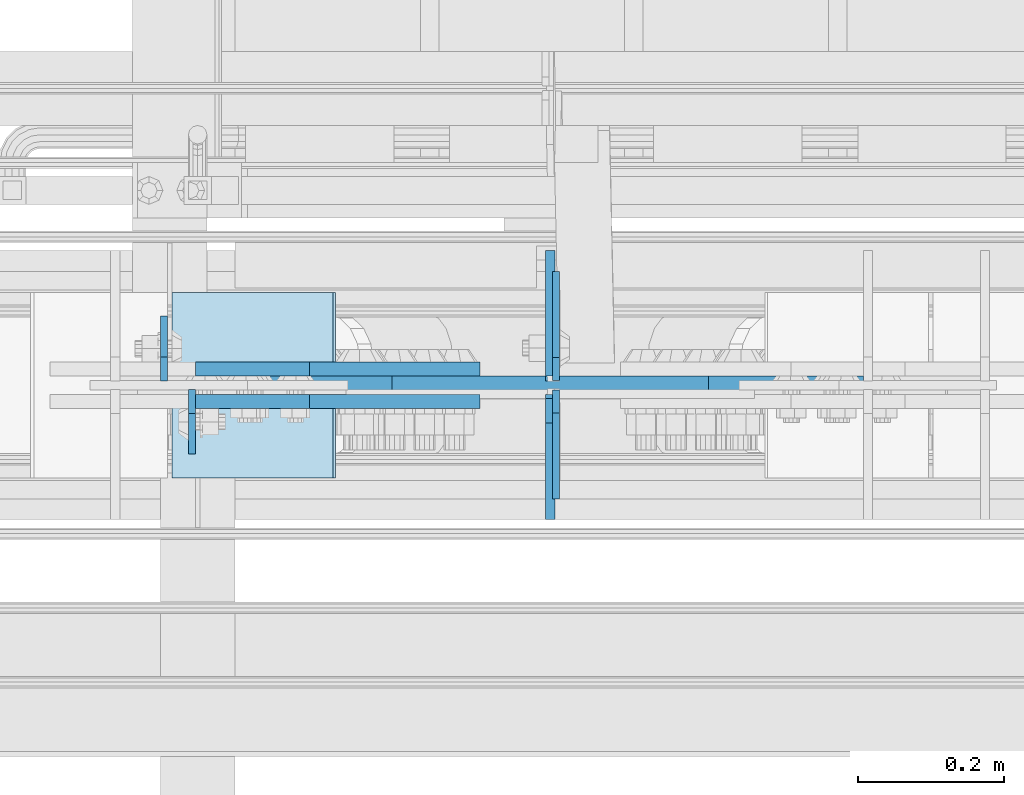
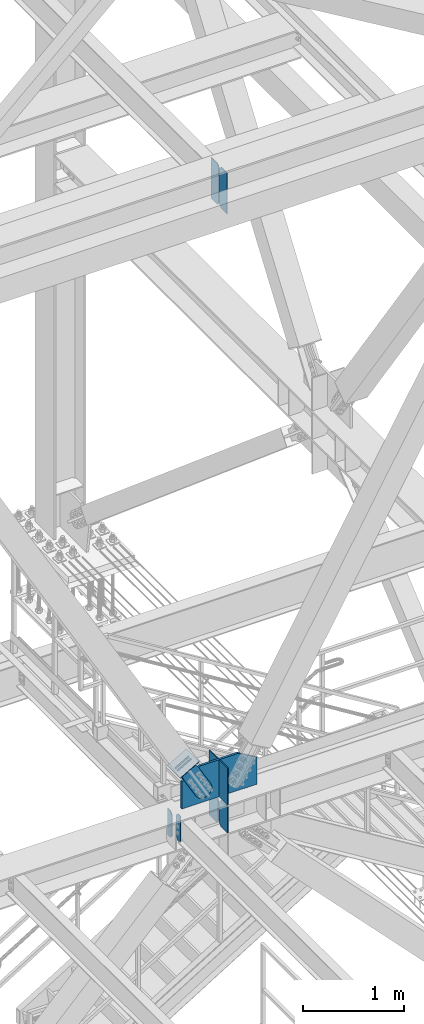
# One storey, part 3551 of 3843: 12 plates, 5 elements without a shape of their own.
"""IFC2X3 building model written with IfcOpenShell, lengths in millimetres."""

from ifc_helpers import new_model, si_unit, frame, origin_with_axes, place, context, subcontext, project, spatial, faceted_brep, material, type_object, element, aggregate, save


model = new_model("IFC2X3")

# Units and contexts
model_context = context("Model", 3, precision=1e-05, world=origin_with_axes())
body_context = subcontext(model_context, "Body", "Model", "MODEL_VIEW")
ifc_project = project(units=[si_unit("LENGTHUNIT", "METRE", prefix="MILLI"), si_unit("AREAUNIT", "SQUARE_METRE"), si_unit("VOLUMEUNIT", "CUBIC_METRE"), si_unit("MASSUNIT", "GRAM", prefix="KILO"), si_unit("TIMEUNIT", "SECOND"), si_unit("PLANEANGLEUNIT", "RADIAN"), si_unit("SOLIDANGLEUNIT", "STERADIAN"), si_unit("THERMODYNAMICTEMPERATUREUNIT", "DEGREE_CELSIUS"), si_unit("LUMINOUSINTENSITYUNIT", "LUMEN")], contexts=[model_context])

# Site, building, storey
site_placement = place(None, origin_with_axes())
site = spatial("IfcSite", under=ifc_project, at=site_placement, CompositionType="ELEMENT")
building_placement = place(site_placement, origin_with_axes())
building = spatial("IfcBuilding", under=site, at=building_placement, Name="Undefined", CompositionType="ELEMENT")
storey_placement = place(building_placement, origin_with_axes())
storey = spatial("IfcBuildingStorey", under=building, at=storey_placement, Name="Undefined", CompositionType="ELEMENT", Elevation=0.0)

# Assembly, plates
assembly_1_placement = place(storey_placement, origin_with_axes())
assembly_1 = element("IfcElementAssembly", 1, at=assembly_1_placement, inside=storey, Name="BEAM", AssemblyPlace="NOTDEFINED", PredefinedType="RIGID_FRAME")
ifc_material_1 = material(Name="STEEL/A572-50")
plate_type_1 = type_object("IfcPlateType", PredefinedType="NOTDEFINED")
plate_1_placement = place(assembly_1_placement, frame((80840.2625000477, 14993.14375, 34791.65), z_axis=(0.0, -1.0, 0.0), x_axis=(0.0, 0.0, -1.0)))
plate_1 = element("IfcPlate", 2, at=plate_1_placement, type_object=plate_type_1, material=ifc_material_1, Name="PLATE", context=body_context, shape_type="Brep", body=[
    faceted_brep([(0.0, -4.76249999999709, 33.3375015258789), (0.0, -4.76249999999709, 88.9000015258789), (0.0, 4.76249999999709, 88.9000015258789), (0.0, 4.76249999999709, 33.3375015258789), (317.5, -4.76249999999709, 88.8999984741204), (317.5, 4.76249999999709, 88.8999984741204), (317.5, -4.76249999999709, 33.3375015258789), (317.5, 4.76249999999709, 33.3375015258789), (284.162498474121, -4.76249999999709, 0.0), (284.162498474121, 4.76249999999709, 0.0), (33.3375015258789, -4.76249999999709, 0.0), (33.3375015258789, 4.76249999999709, 0.0)], [[[0, 1, 2, 3]], [[1, 4, 5, 2]], [[4, 6, 7, 5]], [[6, 8, 9, 7]], [[8, 10, 11, 9]], [[10, 0, 3, 11]], [[5, 7, 9, 11, 3, 2]], [[10, 8, 6, 4, 1, 0]]]),
])
plate_2_placement = place(assembly_1_placement, frame((80802.1625000477, 15004.25625, 34791.65), z_axis=(0.0, 1.0, 0.0), x_axis=(0.0, 0.0, -1.0)))
plate_2 = element("IfcPlate", 3, at=plate_2_placement, type_object=plate_type_1, material=ifc_material_1, Name="PLATE", context=body_context, shape_type="Brep", body=[
    faceted_brep([(0.0, -4.76249999999709, 33.3375015258789), (0.0, -4.76249999999709, 88.9000015258789), (0.0, 4.76249999999709, 88.9000015258789), (0.0, 4.76249999999709, 33.3375015258789), (317.5, -4.76249999999709, 88.8999984741204), (317.5, 4.76249999999709, 88.8999984741204), (317.5, -4.76249999999709, 33.3375015258789), (317.5, 4.76249999999709, 33.3375015258789), (284.162498474121, -4.76249999999709, 0.0), (284.162498474121, 4.76249999999709, 0.0), (33.3375015258789, -4.76249999999709, 0.0), (33.3375015258789, 4.76249999999709, 0.0)], [[[0, 1, 2, 3]], [[1, 4, 5, 2]], [[4, 6, 7, 5]], [[6, 8, 9, 7]], [[8, 10, 11, 9]], [[10, 0, 3, 11]], [[5, 7, 9, 11, 3, 2]], [[10, 8, 6, 4, 1, 0]]]),
])

assembly_2_placement = place(storey_placement, origin_with_axes())
assembly_2 = element("IfcElementAssembly", 4, at=assembly_2_placement, inside=storey, Name="BEAM", AssemblyPlace="NOTDEFINED", PredefinedType="RIGID_FRAME")
plate_type_2 = type_object("IfcPlateType", PredefinedType="NOTDEFINED")
plate_3_placement = place(assembly_2_placement, frame((81338.7379999161, 14992.35, 41948.1), z_axis=(0.0, 0.0, 1.0), x_axis=(0.0, -1.0, 0.0)))
plate_3 = element("IfcPlate", 5, at=plate_3_placement, type_object=plate_type_2, material=ifc_material_1, Name="PLATE", context=body_context, shape_type="Brep", body=[
    faceted_brep([(0.0, -4.76249999999709, 31.75), (0.0, -4.76249999999709, 466.724999999999), (0.0, 4.76249999999709, 466.724999999999), (0.0, 4.76249999999709, 31.75), (31.75, -4.76249999999709, 498.474999999999), (31.75, 4.76249999999709, 498.474999999999), (149.224999999977, -4.76249999999709, 498.474999999999), (149.224999999977, 4.76249999999709, 498.474999999999), (149.224999999977, -4.76249999999709, 0.0), (149.224999999977, 4.76249999999709, 0.0), (31.75, -4.76249999999709, 0.0), (31.75, 4.76249999999709, 0.0)], [[[0, 1, 2, 3]], [[1, 4, 5, 2]], [[4, 6, 7, 5]], [[6, 8, 9, 7]], [[8, 10, 11, 9]], [[10, 0, 3, 11]], [[5, 7, 9, 11, 3, 2]], [[10, 8, 6, 4, 1, 0]]]),
])
plate_4_placement = place(assembly_2_placement, frame((81338.7379999161, 15005.05, 41948.1), z_axis=(0.0, 0.0, 1.0), x_axis=(0.0, 1.0, 0.0)))
plate_4 = element("IfcPlate", 6, at=plate_4_placement, type_object=plate_type_2, material=ifc_material_1, Name="PLATE", context=body_context, shape_type="Brep", body=[
    faceted_brep([(0.0, -4.76249999999709, 31.75), (0.0, -4.76249999999709, 466.724999999999), (0.0, 4.76249999999709, 466.724999999999), (0.0, 4.76249999999709, 31.75), (31.75, -4.76249999999709, 498.474999999999), (31.75, 4.76249999999709, 498.474999999999), (149.224999999977, -4.76249999999709, 498.474999999999), (149.224999999977, 4.76249999999709, 498.474999999999), (149.224999999977, -4.76249999999709, 0.0), (149.224999999977, 4.76249999999709, 0.0), (31.75, -4.76249999999709, 0.0), (31.75, 4.76249999999709, 0.0)], [[[0, 1, 2, 3]], [[1, 4, 5, 2]], [[4, 6, 7, 5]], [[6, 8, 9, 7]], [[8, 10, 11, 9]], [[10, 0, 3, 11]], [[5, 7, 9, 11, 3, 2]], [[10, 8, 6, 4, 1, 0]]]),
])
aggregate(assembly_2, [plate_3, plate_4])

# Plate
plate_type_3 = type_object("IfcPlateType", PredefinedType="NOTDEFINED")
plate_5_placement = place(assembly_1_placement, frame((81330.7999999999, 15004.25625, 34474.15), z_axis=(0.0, 1.0, 0.0), x_axis=(0.0, 0.0, 1.0)))
plate_5 = element("IfcPlate", 7, at=plate_5_placement, type_object=plate_type_3, material=ifc_material_1, Name="CB_BEAM", context=body_context, shape_type="Brep", body=[
    faceted_brep([(0.0, -6.34999999999854, 33.3375015258789), (0.0, -6.34999999999854, 178.59375), (0.0, 6.34999999999854, 178.59375), (0.0, 6.34999999999854, 33.3375015258789), (317.499999999985, -6.34999999999854, 178.59375), (317.499999999985, 6.34999999999854, 178.59375), (317.499999999985, -6.34999999999854, 33.3375015258789), (317.499999999985, 6.34999999999854, 33.3375015258789), (284.162498474107, -6.34999999999854, 0.0), (284.162498474107, 6.34999999999854, 0.0), (33.3375015258789, -6.34999999999854, 0.0), (33.3375015258789, 6.34999999999854, 0.0)], [[[0, 1, 2, 3]], [[1, 4, 5, 2]], [[4, 6, 7, 5]], [[6, 8, 9, 7]], [[8, 10, 11, 9]], [[10, 0, 3, 11]], [[5, 7, 9, 11, 3, 2]], [[10, 8, 6, 4, 1, 0]]]),
])

# Assembly, plate
assembly_3_placement = place(storey_placement, origin_with_axes())
assembly_3 = element("IfcElementAssembly", 8, at=assembly_3_placement, inside=storey, AssemblyPlace="NOTDEFINED", PredefinedType="RIGID_FRAME")
ifc_material_2 = material(Name="STEEL/A36")
plate_type_4 = type_object("IfcPlateType", PredefinedType="NOTDEFINED")
plate_6_placement = place(assembly_3_placement, frame((81001.1462213866, 15020.925, 35391.593268271), z_axis=(-0.868467373134184, 0.0, -0.495746328076577), x_axis=(0.495746328076598, 0.0, -0.868467373134173)))
plate_6 = element("IfcPlate", 9, at=plate_6_placement, type_object=plate_type_4, material=ifc_material_2, context=body_context, shape_type="Brep", body=[
    faceted_brep([(0.0, -9.52500000000146, 0.0), (7.37782102078199e-09, -9.52499999999418, 179.651701450231), (7.37782102078199e-09, 9.52499999999418, 179.651701450231), (0.0, 9.52500000000146, 0.0), (69.8500000062704, -9.52499999999418, 179.651701450392), (69.8500000062704, 9.52499999999418, 179.651701450392), (171.449999998309, -9.52499999999418, 186.663350727089), (171.449999998309, 9.52499999999418, 186.663350727089), (434.579297655291, -9.52499999999418, 186.663350728457), (434.579297655291, 9.52499999999418, 186.663350728457), (471.637405120986, -9.52499999999418, 179.292034842016), (471.637405120986, 9.52499999999418, 179.292034842016), (503.05375165752, -9.52499999999418, 158.300303204887), (503.05375165752, 9.52499999999418, 158.300303204887), (524.045483294532, -9.52499999999418, 126.883956668345), (524.045483294532, 9.52499999999418, 126.883956668345), (531.416799180792, -9.52499999999418, 89.8258522538526), (531.416799180792, 9.52499999999418, 89.8258522538526), (524.045483293885, -9.52499999999418, 52.7677447886235), (524.045483293885, 9.52499999999418, 52.7677447886235), (503.053751656611, -9.52499999999418, 21.3513982523873), (503.053751656611, 9.52499999999418, 21.3513982523873), (471.637405120178, -9.52499999999418, 0.359666615346214), (471.637405120178, 9.52499999999418, 0.359666615346214), (434.579299181831, -9.52499999999418, -7.01164927131322), (434.579299181831, 9.52499999999418, -7.01164927131322), (171.449999996272, -9.52499999999418, -7.01164927269565), (171.449999996272, 9.52499999999418, -7.01164927269565), (69.8499999979995, -9.52499999999418, -4.00177668780088e-10), (69.8499999979995, 9.52499999999418, -4.00177668780088e-10)], [[[0, 1, 2, 3]], [[1, 4, 5, 2]], [[4, 6, 7, 5]], [[6, 8, 9, 7]], [[8, 10, 11, 9]], [[10, 12, 13, 11]], [[12, 14, 15, 13]], [[14, 16, 17, 15]], [[16, 18, 19, 17]], [[18, 20, 21, 19]], [[20, 22, 23, 21]], [[22, 24, 25, 23]], [[24, 26, 27, 25]], [[26, 28, 29, 27]], [[28, 0, 3, 29]], [[5, 7, 9, 11, 13, 15, 17, 19, 21, 23, 25, 27, 29, 3, 2]], [[28, 26, 24, 22, 20, 18, 16, 14, 12, 10, 8, 6, 4, 1, 0]]]),
])
aggregate(assembly_3, [plate_6])

assembly_4_placement = place(storey_placement, origin_with_axes())
assembly_4 = element("IfcElementAssembly", 10, at=assembly_4_placement, inside=storey, AssemblyPlace="NOTDEFINED", PredefinedType="RIGID_FRAME")
plate_7_placement = place(assembly_4_placement, frame((81001.1462213866, 14976.475, 35391.593268271), z_axis=(-0.868467373134184, 0.0, -0.495746328076577), x_axis=(0.495746328076598, 0.0, -0.868467373134173)))
plate_7 = element("IfcPlate", 11, at=plate_7_placement, type_object=plate_type_4, material=ifc_material_2, context=body_context, shape_type="Brep", body=[
    faceted_brep([(0.0, -9.52500000000146, 0.0), (7.37782102078199e-09, -9.52499999999418, 179.651701450231), (7.37782102078199e-09, 9.52499999999418, 179.651701450231), (0.0, 9.52500000000146, 0.0), (69.8500000062704, -9.52499999999418, 179.651701450392), (69.8500000062704, 9.52499999999418, 179.651701450392), (171.449999998309, -9.52499999999418, 186.663350727089), (171.449999998309, 9.52499999999418, 186.663350727089), (434.579297655291, -9.52499999999418, 186.663350728457), (434.579297655291, 9.52499999999418, 186.663350728457), (471.637405120986, -9.52499999999418, 179.292034842016), (471.637405120986, 9.52499999999418, 179.292034842016), (503.05375165752, -9.52499999999418, 158.300303204887), (503.05375165752, 9.52499999999418, 158.300303204887), (524.045483294532, -9.52499999999418, 126.883956668345), (524.045483294532, 9.52499999999418, 126.883956668345), (531.416799180792, -9.52499999999418, 89.8258522538526), (531.416799180792, 9.52499999999418, 89.8258522538526), (524.045483293885, -9.52499999999418, 52.7677447886235), (524.045483293885, 9.52499999999418, 52.7677447886235), (503.053751656611, -9.52499999999418, 21.3513982523873), (503.053751656611, 9.52499999999418, 21.3513982523873), (471.637405120178, -9.52499999999418, 0.359666615346214), (471.637405120178, 9.52499999999418, 0.359666615346214), (434.579299181831, -9.52499999999418, -7.01164927131322), (434.579299181831, 9.52499999999418, -7.01164927131322), (171.449999996272, -9.52499999999418, -7.01164927269565), (171.449999996272, 9.52499999999418, -7.01164927269565), (69.8499999979995, -9.52499999999418, -4.00177668780088e-10), (69.8499999979995, 9.52499999999418, -4.00177668780088e-10)], [[[0, 1, 2, 3]], [[1, 4, 5, 2]], [[4, 6, 7, 5]], [[6, 8, 9, 7]], [[8, 10, 11, 9]], [[10, 12, 13, 11]], [[12, 14, 15, 13]], [[14, 16, 17, 15]], [[16, 18, 19, 17]], [[18, 20, 21, 19]], [[20, 22, 23, 21]], [[22, 24, 25, 23]], [[24, 26, 27, 25]], [[26, 28, 29, 27]], [[28, 0, 3, 29]], [[5, 7, 9, 11, 13, 15, 17, 19, 21, 23, 25, 27, 29, 3, 2]], [[28, 26, 24, 22, 20, 18, 16, 14, 12, 10, 8, 6, 4, 1, 0]]]),
])
aggregate(assembly_4, [plate_7])

assembly_5_placement = place(storey_placement, origin_with_axes())
assembly_5 = element("IfcElementAssembly", 12, at=assembly_5_placement, inside=storey, Name="Plate", AssemblyPlace="NOTDEFINED", PredefinedType="RIGID_FRAME")
plate_type_5 = type_object("IfcPlateType", PredefinedType="NOTDEFINED")
plate_8_placement = place(assembly_5_placement, frame((80814.41403876, 15125.7, 35281.3452649073), z_axis=(0.868467373134175, 0.0, 0.495746328076595), x_axis=(0.0, -1.0, 0.0)))
plate_8 = element("IfcPlate", 13, at=plate_8_placement, type_object=plate_type_5, material=ifc_material_2, Name="Plate", context=body_context, shape_type="Brep", body=[
    faceted_brep([(0.0, -3.17499999999927, 0.0), (0.0, -3.17499999965185, 254.000000005151), (0.0, 3.17500000035216, 254.000000005166), (0.0, 3.17499999999927, 0.0), (254.0, -3.17499999965185, 254.000000005151), (254.0, 3.17500000035216, 254.000000005166), (254.0, -3.17500000000291, 0.0), (254.0, 3.17499999999927, 1.45519152283669e-11)], [[[0, 1, 2, 3]], [[1, 4, 5, 2]], [[4, 6, 7, 5]], [[6, 0, 3, 7]], [[5, 7, 3, 2]], [[6, 4, 1, 0]]]),
])
aggregate(assembly_5, [plate_8])

# Plate
plate_type_6 = type_object("IfcPlateType", PredefinedType="NOTDEFINED")
plate_9_placement = place(assembly_1_placement, frame((81330.7999999999, 14980.44375, 34474.15), z_axis=(0.0, -1.0, 0.0), x_axis=(0.0, 0.0, 1.0)))
plate_9 = element("IfcPlate", 14, at=plate_9_placement, type_object=plate_type_6, material=ifc_material_1, Name="CB_BEAM", context=body_context, shape_type="Brep", body=[
    faceted_brep([(0.0, -6.34999999999854, 33.3375015258789), (0.0, -6.34999999999854, 165.893750000003), (0.0, 6.34999999999854, 165.893750000003), (0.0, 6.34999999999854, 33.3375015258789), (317.5, -6.34999999999854, 165.893750000003), (317.5, 6.34999999999854, 165.893750000003), (317.499999999985, -6.34999999999854, 33.3375015258789), (317.499999999985, 6.34999999999854, 33.3375015258789), (284.162498474107, -6.34999999999854, 0.0), (284.162498474107, 6.34999999999854, 0.0), (33.3375015258789, -6.34999999999854, 0.0), (33.3375015258789, 6.34999999999854, 0.0)], [[[0, 1, 2, 3]], [[1, 4, 5, 2]], [[4, 6, 7, 5]], [[6, 8, 9, 7]], [[8, 10, 11, 9]], [[10, 0, 3, 11]], [[5, 7, 9, 11, 3, 2]], [[10, 8, 6, 4, 1, 0]]]),
])

plate_type_7 = type_object("IfcPlateType", PredefinedType="NOTDEFINED")
plate_10_placement = place(assembly_1_placement, frame((81330.7999999999, 15011.4, 34810.7), z_axis=(0.0, 1.0, 0.0), x_axis=(0.0, 0.0, 1.0)))
plate_10 = element("IfcPlate", 15, at=plate_10_placement, type_object=plate_type_7, material=ifc_material_1, Name="CB", context=body_context, shape_type="Brep", body=[
    faceted_brep([(0.0, -6.34999999999854, 19.0499992370605), (0.0, -6.35000000000582, 171.449999999999), (0.0, 6.35000000000582, 171.449999999999), (0.0, 6.34999999999854, 19.0499992370605), (448.06249326696, -6.35000000000582, 171.449999999999), (448.06249326696, 6.35000000000582, 171.449999999999), (448.06249326696, -6.35000000000582, 0.0), (448.06249326696, 6.35000000000582, 0.0), (19.0499992370605, -6.34999999999854, 0.0), (19.0499992370605, 6.34999999999854, 0.0)], [[[0, 1, 2, 3]], [[1, 4, 5, 2]], [[4, 6, 7, 5]], [[6, 8, 9, 7]], [[8, 0, 3, 9]], [[5, 7, 9, 3, 2]], [[8, 6, 4, 1, 0]]]),
])

plate_11_placement = place(assembly_1_placement, frame((81330.7999999999, 14986.0, 34810.7), z_axis=(0.0, -1.0, 0.0), x_axis=(0.0, 0.0, 1.0)))
plate_11 = element("IfcPlate", 16, at=plate_11_placement, type_object=plate_type_7, material=ifc_material_1, Name="CB", context=body_context, shape_type="Brep", body=[
    faceted_brep([(0.0, -6.34999999999854, 19.0499992370605), (0.0, -6.35000000000582, 171.449999999999), (0.0, 6.35000000000582, 171.449999999999), (0.0, 6.34999999999854, 19.0499992370605), (448.06249326696, -6.35000000000582, 171.449999999999), (448.06249326696, 6.35000000000582, 171.449999999999), (448.06249326696, -6.35000000000582, 0.0), (448.06249326696, 6.35000000000582, 0.0), (19.0499992370605, -6.34999999999854, 0.0), (19.0499992370605, 6.34999999999854, 0.0)], [[[0, 1, 2, 3]], [[1, 4, 5, 2]], [[4, 6, 7, 5]], [[6, 8, 9, 7]], [[8, 0, 3, 9]], [[5, 7, 9, 3, 2]], [[8, 6, 4, 1, 0]]]),
])

plate_type_8 = type_object("IfcPlateType", PredefinedType="NOTDEFINED")
plate_12_placement = place(assembly_1_placement, frame((80901.9718281895, 14998.7, 34810.7), z_axis=(1.0, 0.0, 0.0), x_axis=(0.0, 0.0, 1.0)))
plate_12 = element("IfcPlate", 17, at=plate_12_placement, type_object=plate_type_8, material=ifc_material_1, Name="CB", context=body_context, shape_type="Brep", body=[
    faceted_brep([(0.0, -12.6999999999971, 0.0), (0.0, -12.7000000000007, 857.656343620678), (0.0, 12.7000000000007, 857.656343620678), (0.0, 12.6999999999971, 0.0), (326.864909710435, -12.7000000000007, 857.656343620678), (326.864909710435, 12.7000000000007, 857.656343620678), (448.06249326696, -12.7000000000007, 645.337782573697), (448.06249326696, 12.7000000000007, 645.337782573697), (448.06249326696, -12.7000000000007, 435.178171810345), (448.06249326696, 12.7000000000007, 435.178171810345), (448.06249326696, -12.7000000000007, 212.318561046981), (448.06249326696, 12.7000000000007, 212.318561046981), (326.864909710435, -12.7000000000007, 0.0), (326.864909710435, 12.7000000000007, 0.0)], [[[0, 1, 2, 3]], [[1, 4, 5, 2]], [[4, 6, 7, 5]], [[6, 8, 9, 7]], [[8, 10, 11, 9]], [[10, 12, 13, 11]], [[12, 0, 3, 13]], [[5, 7, 9, 11, 13, 3, 2]], [[12, 10, 8, 6, 4, 1, 0]]]),
])

aggregate(assembly_1, [plate_5, plate_9, plate_10, plate_11, plate_12, plate_1, plate_2])

save(model, "model.ifc")
